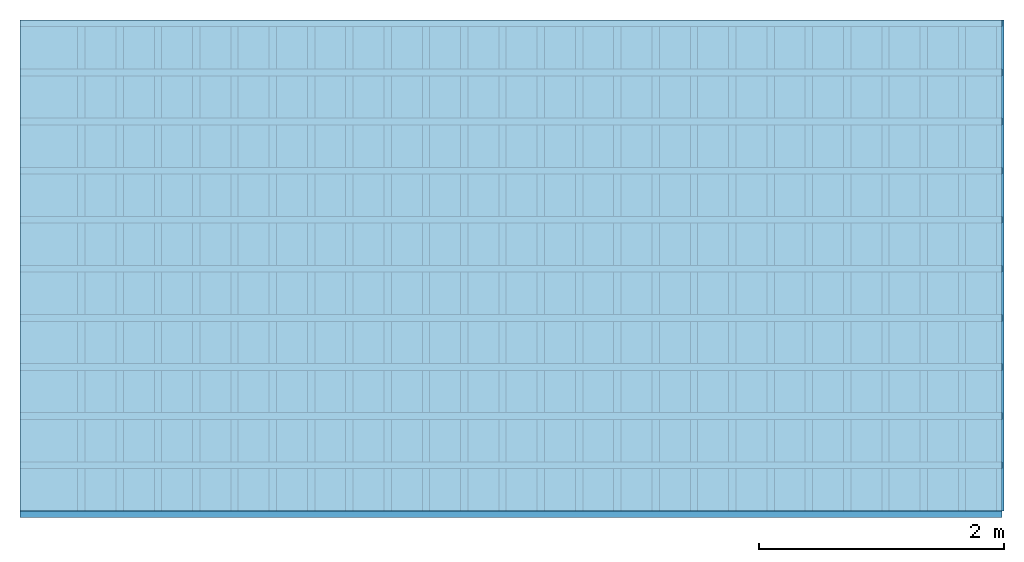
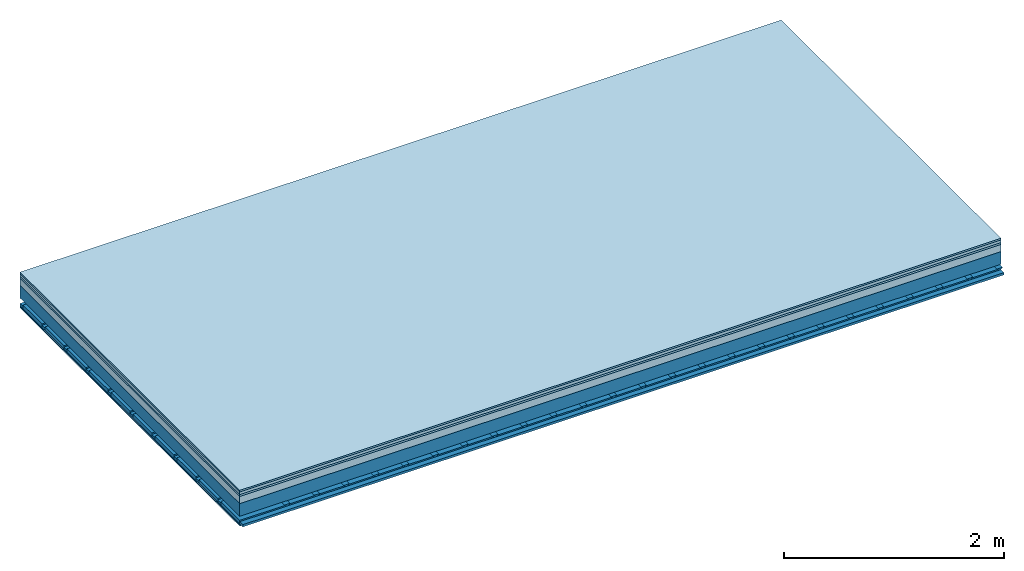
# One storey: 6 plates, 4 members, 1 element without a shape of its own.
"""IFC4 building model written with IfcOpenShell, lengths in metres."""

from ifc_helpers import new_model, si_unit, derived_unit, direction, frame, frame_2d, origin, origin_with_axes, place, context, project, spatial, polyline, rectangle, outline, extrude, material, layer, layer_set, type_object, element, aggregate, save


model = new_model("IFC4")

# Units and contexts
plan_context = context("Plan", 3, precision=1e-05, world=origin(), true_north=direction((0.0, 1.0)))
model_context = context("Model", 3, precision=1e-05, world=origin(), true_north=direction((0.0, 1.0)))
ifc_project = project(units=[si_unit("LENGTHUNIT", "METRE"), derived_unit("SOUNDPRESSUREUNIT", [(si_unit("PRESSUREUNIT", "PASCAL", prefix="MICRO"), 0)]), si_unit("ENERGYUNIT", "JOULE", prefix="MEGA"), si_unit("MASSUNIT", "GRAM", prefix="KILO"), derived_unit("THERMALTRANSMITTANCEUNIT", [(si_unit("POWERUNIT", "WATT"), 1), (si_unit("AREAUNIT", "SQUARE_METRE"), -1), (si_unit("THERMODYNAMICTEMPERATUREUNIT", "KELVIN"), -1)]), derived_unit("AREADENSITYUNIT", [(si_unit("MASSUNIT", "GRAM", prefix="KILO"), 1), (si_unit("AREAUNIT", "SQUARE_METRE"), -1)]), derived_unit("USERDEFINED", [(si_unit("ENERGYUNIT", "JOULE", prefix="MEGA"), 1), (si_unit("AREAUNIT", "SQUARE_METRE"), -1)])], contexts=[plan_context, model_context])

# Site, building, storey
site = spatial("IfcSite", under=ifc_project)
building_placement = place(None, origin())
building = spatial("IfcBuilding", under=site, at=building_placement)
storey_placement = place(building_placement, origin())
storey = spatial("IfcBuildingStorey", under=building, at=storey_placement)

# Slab, members, plates
ifc_material_1 = material(Name="Floor heating system Therm38 longitudinal", Category="03.007")
ifc_layer_1 = layer(ifc_material_1, 0.018, Name="Flooring")
ifc_material_2 = material(Name="Phone Star TRI", Category="03.013")
ifc_layer_2 = layer(ifc_material_2, 0.03, Name="On-material")
ifc_material_3 = material(Name="EP3")
ifc_layer_3 = layer(ifc_material_3, 0.02, Name="Impact sound insulation")
ifc_material_4 = material(Category="03.011")
ifc_layer_4 = layer(ifc_material_4, 0.08, Name="on Supporting structure")
ifc_material_5 = material(Name="no composite action")
ifc_layer_5 = layer(ifc_material_5, 0.0, Name="Bond")
ifc_layer_6 = layer(None, 0.14, Name="Supporting structure")
ifc_material_6 = material(Name="of the art")
ifc_layer_7 = layer(ifc_material_6, 0.0, Name="Bond")
ifc_layer_8 = layer(None, 0.06, Name="Coupling")
ifc_layer_9 = layer(None, 0.025, Name="Battens / profiles")
ifc_layer_10 = layer(ifc_material_2, 0.0125, Name="Ceiling covering 1st layer")
ifc_material_7 = material(Name="Plasterboard type A", Category="03.008")
ifc_layer_11 = layer(ifc_material_7, 0.0125, Name="Ceiling covering layer 2")
ifc_material_8 = material(Name="joints", Category="04.017")
ifc_layer_12 = layer(ifc_material_8, 0.0, Name="Surface / treatment")
ifc_layer_set = layer_set([ifc_layer_1, ifc_layer_2, ifc_layer_3, ifc_layer_4, ifc_layer_5, ifc_layer_6, ifc_layer_7, ifc_layer_8, ifc_layer_9, ifc_layer_10, ifc_layer_11, ifc_layer_12])
slab_type = type_object("IfcSlabType", Name="A2453", PredefinedType="NOTDEFINED", material=ifc_layer_set)
slab_placement = place(None, frame((0.0, 0.0, 0.0), z_axis=(0.0, 0.0, -1.0), x_axis=(1.0, 0.0, 0.0)))
slab = element("IfcSlab", 1, at=slab_placement, inside=storey, type_object=slab_type, material=ifc_layer_set, Name="Slab #1")
ifc_material_9 = material()
member_1_placement = place(slab_placement, origin())
member_1 = element("IfcMember", 2, at=member_1_placement, material=ifc_material_9, Name="Supporting structure", context=plan_context, shape_type="SweptSolid", body=[
    extrude(rectangle(XDim=1.0, YDim=0.14, at=frame_2d((0.5, 0.07), x_axis=(1.0, 0.0))), frame((0.0, 4.0, 0.148), z_axis=(0.0, -1.0, 0.0), x_axis=(1.0, 0.0, 0.0)), (0.0, 0.0, 1.0), 4.0),
    extrude(rectangle(XDim=1.0, YDim=0.14, at=frame_2d((0.5, 0.07), x_axis=(1.0, 0.0))), frame((1.0, 4.0, 0.148), z_axis=(0.0, -1.0, 0.0), x_axis=(1.0, 0.0, 0.0)), (0.0, 0.0, 1.0), 4.0),
    extrude(rectangle(XDim=1.0, YDim=0.14, at=frame_2d((0.5, 0.07), x_axis=(1.0, 0.0))), frame((2.0, 4.0, 0.148), z_axis=(0.0, -1.0, 0.0), x_axis=(1.0, 0.0, 0.0)), (0.0, 0.0, 1.0), 4.0),
    extrude(rectangle(XDim=1.0, YDim=0.14, at=frame_2d((0.5, 0.07), x_axis=(1.0, 0.0))), frame((3.0, 4.0, 0.148), z_axis=(0.0, -1.0, 0.0), x_axis=(1.0, 0.0, 0.0)), (0.0, 0.0, 1.0), 4.0),
    extrude(rectangle(XDim=1.0, YDim=0.14, at=frame_2d((0.5, 0.07), x_axis=(1.0, 0.0))), frame((4.0, 4.0, 0.148), z_axis=(0.0, -1.0, 0.0), x_axis=(1.0, 0.0, 0.0)), (0.0, 0.0, 1.0), 4.0),
    extrude(rectangle(XDim=1.0, YDim=0.14, at=frame_2d((0.5, 0.07), x_axis=(1.0, 0.0))), frame((5.0, 4.0, 0.148), z_axis=(0.0, -1.0, 0.0), x_axis=(1.0, 0.0, 0.0)), (0.0, 0.0, 1.0), 4.0),
    extrude(rectangle(XDim=1.0, YDim=0.14, at=frame_2d((0.5, 0.07), x_axis=(1.0, 0.0))), frame((6.0, 4.0, 0.148), z_axis=(0.0, -1.0, 0.0), x_axis=(1.0, 0.0, 0.0)), (0.0, 0.0, 1.0), 4.0),
    extrude(rectangle(XDim=1.0, YDim=0.14, at=frame_2d((0.5, 0.07), x_axis=(1.0, 0.0))), frame((7.0, 4.0, 0.148), z_axis=(0.0, -1.0, 0.0), x_axis=(1.0, 0.0, 0.0)), (0.0, 0.0, 1.0), 4.0),
])
ifc_material_10 = material()
member_2_placement = place(slab_placement, origin())
member_2 = element("IfcMember", 3, at=member_2_placement, material=ifc_material_10, Name="Coupling", context=plan_context, shape_type="SweptSolid", body=[
    extrude(outline(polyline([(0.0, 0.0), (0.06, 0.0), (0.04, 0.02), (0.02, 0.02), (0.0, 0.0)])), frame((0.47, 4.0, 0.328), z_axis=(0.0, -1.0, 0.0), x_axis=(1.0, 0.0, 0.0)), (0.0, 0.0, 1.0), 4.0),
    extrude(outline(polyline([(0.0, 0.0), (0.06, 0.0), (0.04, 0.02), (0.02, 0.02), (0.0, 0.0)])), frame((0.782, 4.0, 0.328), z_axis=(0.0, -1.0, 0.0), x_axis=(1.0, 0.0, 0.0)), (0.0, 0.0, 1.0), 4.0),
    extrude(outline(polyline([(0.0, 0.0), (0.06, 0.0), (0.04, 0.02), (0.02, 0.02), (0.0, 0.0)])), frame((1.094, 4.0, 0.328), z_axis=(0.0, -1.0, 0.0), x_axis=(1.0, 0.0, 0.0)), (0.0, 0.0, 1.0), 4.0),
    extrude(outline(polyline([(0.0, 0.0), (0.06, 0.0), (0.04, 0.02), (0.02, 0.02), (0.0, 0.0)])), frame((1.406, 4.0, 0.328), z_axis=(0.0, -1.0, 0.0), x_axis=(1.0, 0.0, 0.0)), (0.0, 0.0, 1.0), 4.0),
    extrude(outline(polyline([(0.0, 0.0), (0.06, 0.0), (0.04, 0.02), (0.02, 0.02), (0.0, 0.0)])), frame((1.718, 4.0, 0.328), z_axis=(0.0, -1.0, 0.0), x_axis=(1.0, 0.0, 0.0)), (0.0, 0.0, 1.0), 4.0),
    extrude(outline(polyline([(0.0, 0.0), (0.06, 0.0), (0.04, 0.02), (0.02, 0.02), (0.0, 0.0)])), frame((2.03, 4.0, 0.328), z_axis=(0.0, -1.0, 0.0), x_axis=(1.0, 0.0, 0.0)), (0.0, 0.0, 1.0), 4.0),
    extrude(outline(polyline([(0.0, 0.0), (0.06, 0.0), (0.04, 0.02), (0.02, 0.02), (0.0, 0.0)])), frame((2.342, 4.0, 0.328), z_axis=(0.0, -1.0, 0.0), x_axis=(1.0, 0.0, 0.0)), (0.0, 0.0, 1.0), 4.0),
    extrude(outline(polyline([(0.0, 0.0), (0.06, 0.0), (0.04, 0.02), (0.02, 0.02), (0.0, 0.0)])), frame((2.654, 4.0, 0.328), z_axis=(0.0, -1.0, 0.0), x_axis=(1.0, 0.0, 0.0)), (0.0, 0.0, 1.0), 4.0),
    extrude(outline(polyline([(0.0, 0.0), (0.06, 0.0), (0.04, 0.02), (0.02, 0.02), (0.0, 0.0)])), frame((2.966, 4.0, 0.328), z_axis=(0.0, -1.0, 0.0), x_axis=(1.0, 0.0, 0.0)), (0.0, 0.0, 1.0), 4.0),
    extrude(outline(polyline([(0.0, 0.0), (0.06, 0.0), (0.04, 0.02), (0.02, 0.02), (0.0, 0.0)])), frame((3.278, 4.0, 0.328), z_axis=(0.0, -1.0, 0.0), x_axis=(1.0, 0.0, 0.0)), (0.0, 0.0, 1.0), 4.0),
    extrude(outline(polyline([(0.0, 0.0), (0.06, 0.0), (0.04, 0.02), (0.02, 0.02), (0.0, 0.0)])), frame((3.59, 4.0, 0.328), z_axis=(0.0, -1.0, 0.0), x_axis=(1.0, 0.0, 0.0)), (0.0, 0.0, 1.0), 4.0),
    extrude(outline(polyline([(0.0, 0.0), (0.06, 0.0), (0.04, 0.02), (0.02, 0.02), (0.0, 0.0)])), frame((3.902, 4.0, 0.328), z_axis=(0.0, -1.0, 0.0), x_axis=(1.0, 0.0, 0.0)), (0.0, 0.0, 1.0), 4.0),
    extrude(outline(polyline([(0.0, 0.0), (0.06, 0.0), (0.04, 0.02), (0.02, 0.02), (0.0, 0.0)])), frame((4.214, 4.0, 0.328), z_axis=(0.0, -1.0, 0.0), x_axis=(1.0, 0.0, 0.0)), (0.0, 0.0, 1.0), 4.0),
    extrude(outline(polyline([(0.0, 0.0), (0.06, 0.0), (0.04, 0.02), (0.02, 0.02), (0.0, 0.0)])), frame((4.526, 4.0, 0.328), z_axis=(0.0, -1.0, 0.0), x_axis=(1.0, 0.0, 0.0)), (0.0, 0.0, 1.0), 4.0),
    extrude(outline(polyline([(0.0, 0.0), (0.06, 0.0), (0.04, 0.02), (0.02, 0.02), (0.0, 0.0)])), frame((4.838, 4.0, 0.328), z_axis=(0.0, -1.0, 0.0), x_axis=(1.0, 0.0, 0.0)), (0.0, 0.0, 1.0), 4.0),
    extrude(outline(polyline([(0.0, 0.0), (0.06, 0.0), (0.04, 0.02), (0.02, 0.02), (0.0, 0.0)])), frame((5.15, 4.0, 0.328), z_axis=(0.0, -1.0, 0.0), x_axis=(1.0, 0.0, 0.0)), (0.0, 0.0, 1.0), 4.0),
    extrude(outline(polyline([(0.0, 0.0), (0.06, 0.0), (0.04, 0.02), (0.02, 0.02), (0.0, 0.0)])), frame((5.462, 4.0, 0.328), z_axis=(0.0, -1.0, 0.0), x_axis=(1.0, 0.0, 0.0)), (0.0, 0.0, 1.0), 4.0),
    extrude(outline(polyline([(0.0, 0.0), (0.06, 0.0), (0.04, 0.02), (0.02, 0.02), (0.0, 0.0)])), frame((5.774, 4.0, 0.328), z_axis=(0.0, -1.0, 0.0), x_axis=(1.0, 0.0, 0.0)), (0.0, 0.0, 1.0), 4.0),
    extrude(outline(polyline([(0.0, 0.0), (0.06, 0.0), (0.04, 0.02), (0.02, 0.02), (0.0, 0.0)])), frame((6.086, 4.0, 0.328), z_axis=(0.0, -1.0, 0.0), x_axis=(1.0, 0.0, 0.0)), (0.0, 0.0, 1.0), 4.0),
    extrude(outline(polyline([(0.0, 0.0), (0.06, 0.0), (0.04, 0.02), (0.02, 0.02), (0.0, 0.0)])), frame((6.398, 4.0, 0.328), z_axis=(0.0, -1.0, 0.0), x_axis=(1.0, 0.0, 0.0)), (0.0, 0.0, 1.0), 4.0),
    extrude(outline(polyline([(0.0, 0.0), (0.06, 0.0), (0.04, 0.02), (0.02, 0.02), (0.0, 0.0)])), frame((6.71, 4.0, 0.328), z_axis=(0.0, -1.0, 0.0), x_axis=(1.0, 0.0, 0.0)), (0.0, 0.0, 1.0), 4.0),
    extrude(outline(polyline([(0.0, 0.0), (0.06, 0.0), (0.04, 0.02), (0.02, 0.02), (0.0, 0.0)])), frame((7.022, 4.0, 0.328), z_axis=(0.0, -1.0, 0.0), x_axis=(1.0, 0.0, 0.0)), (0.0, 0.0, 1.0), 4.0),
    extrude(outline(polyline([(0.0, 0.0), (0.06, 0.0), (0.04, 0.02), (0.02, 0.02), (0.0, 0.0)])), frame((7.334, 4.0, 0.328), z_axis=(0.0, -1.0, 0.0), x_axis=(1.0, 0.0, 0.0)), (0.0, 0.0, 1.0), 4.0),
    extrude(outline(polyline([(0.0, 0.0), (0.06, 0.0), (0.04, 0.02), (0.02, 0.02), (0.0, 0.0)])), frame((7.646, 4.0, 0.328), z_axis=(0.0, -1.0, 0.0), x_axis=(1.0, 0.0, 0.0)), (0.0, 0.0, 1.0), 4.0),
    extrude(outline(polyline([(0.0, 0.0), (0.06, 0.0), (0.04, 0.02), (0.02, 0.02), (0.0, 0.0)])), frame((7.958, 4.0, 0.328), z_axis=(0.0, -1.0, 0.0), x_axis=(1.0, 0.0, 0.0)), (0.0, 0.0, 1.0), 4.0),
])
ifc_material_11 = material()
member_3_placement = place(slab_placement, origin())
member_3 = element("IfcMember", 4, at=member_3_placement, material=ifc_material_11, Name="Battens / profiles", context=plan_context, shape_type="SweptSolid", body=[
    extrude(rectangle(XDim=0.055, YDim=0.025, at=frame_2d((0.0275, 0.0125), x_axis=(1.0, 0.0))), frame((0.0, 0.0, 0.348), z_axis=(1.0, 0.0, 0.0), x_axis=(0.0, 1.0, 0.0)), (0.0, 0.0, 1.0), 8.0),
    extrude(rectangle(XDim=0.055, YDim=0.025, at=frame_2d((0.0275, 0.0125), x_axis=(1.0, 0.0))), frame((0.0, 0.4, 0.348), z_axis=(1.0, 0.0, 0.0), x_axis=(0.0, 1.0, 0.0)), (0.0, 0.0, 1.0), 8.0),
    extrude(rectangle(XDim=0.055, YDim=0.025, at=frame_2d((0.0275, 0.0125), x_axis=(1.0, 0.0))), frame((0.0, 0.8, 0.348), z_axis=(1.0, 0.0, 0.0), x_axis=(0.0, 1.0, 0.0)), (0.0, 0.0, 1.0), 8.0),
    extrude(rectangle(XDim=0.055, YDim=0.025, at=frame_2d((0.0275, 0.0125), x_axis=(1.0, 0.0))), frame((0.0, 1.2, 0.348), z_axis=(1.0, 0.0, 0.0), x_axis=(0.0, 1.0, 0.0)), (0.0, 0.0, 1.0), 8.0),
    extrude(rectangle(XDim=0.055, YDim=0.025, at=frame_2d((0.0275, 0.0125), x_axis=(1.0, 0.0))), frame((0.0, 1.6, 0.348), z_axis=(1.0, 0.0, 0.0), x_axis=(0.0, 1.0, 0.0)), (0.0, 0.0, 1.0), 8.0),
    extrude(rectangle(XDim=0.055, YDim=0.025, at=frame_2d((0.0275, 0.0125), x_axis=(1.0, 0.0))), frame((0.0, 2.0, 0.348), z_axis=(1.0, 0.0, 0.0), x_axis=(0.0, 1.0, 0.0)), (0.0, 0.0, 1.0), 8.0),
    extrude(rectangle(XDim=0.055, YDim=0.025, at=frame_2d((0.0275, 0.0125), x_axis=(1.0, 0.0))), frame((0.0, 2.4, 0.348), z_axis=(1.0, 0.0, 0.0), x_axis=(0.0, 1.0, 0.0)), (0.0, 0.0, 1.0), 8.0),
    extrude(rectangle(XDim=0.055, YDim=0.025, at=frame_2d((0.0275, 0.0125), x_axis=(1.0, 0.0))), frame((0.0, 2.8, 0.348), z_axis=(1.0, 0.0, 0.0), x_axis=(0.0, 1.0, 0.0)), (0.0, 0.0, 1.0), 8.0),
    extrude(rectangle(XDim=0.055, YDim=0.025, at=frame_2d((0.0275, 0.0125), x_axis=(1.0, 0.0))), frame((0.0, 3.2, 0.348), z_axis=(1.0, 0.0, 0.0), x_axis=(0.0, 1.0, 0.0)), (0.0, 0.0, 1.0), 8.0),
    extrude(rectangle(XDim=0.055, YDim=0.025, at=frame_2d((0.0275, 0.0125), x_axis=(1.0, 0.0))), frame((0.0, 3.6, 0.348), z_axis=(1.0, 0.0, 0.0), x_axis=(0.0, 1.0, 0.0)), (0.0, 0.0, 1.0), 8.0),
    extrude(rectangle(XDim=0.055, YDim=0.025, at=frame_2d((0.0275, 0.0125), x_axis=(1.0, 0.0))), frame((0.0, 4.0, 0.348), z_axis=(1.0, 0.0, 0.0), x_axis=(0.0, 1.0, 0.0)), (0.0, 0.0, 1.0), 8.0),
])
ifc_material_12 = material()
member_4_placement = place(slab_placement, origin())
member_4 = element("IfcMember", 5, at=member_4_placement, material=ifc_material_12, Name="Cavity", context=plan_context, shape_type="SweptSolid", body=[
    extrude(rectangle(XDim=0.345, YDim=0.04, at=frame_2d((0.1725, 0.02), x_axis=(1.0, 0.0))), frame((0.0, 0.055, 0.333), z_axis=(1.0, 0.0, 0.0), x_axis=(0.0, 1.0, 0.0)), (0.0, 0.0, 1.0), 8.0),
    extrude(rectangle(XDim=0.345, YDim=0.04, at=frame_2d((0.1725, 0.02), x_axis=(1.0, 0.0))), frame((0.0, 0.455, 0.333), z_axis=(1.0, 0.0, 0.0), x_axis=(0.0, 1.0, 0.0)), (0.0, 0.0, 1.0), 8.0),
    extrude(rectangle(XDim=0.345, YDim=0.04, at=frame_2d((0.1725, 0.02), x_axis=(1.0, 0.0))), frame((0.0, 0.855, 0.333), z_axis=(1.0, 0.0, 0.0), x_axis=(0.0, 1.0, 0.0)), (0.0, 0.0, 1.0), 8.0),
    extrude(rectangle(XDim=0.345, YDim=0.04, at=frame_2d((0.1725, 0.02), x_axis=(1.0, 0.0))), frame((0.0, 1.255, 0.333), z_axis=(1.0, 0.0, 0.0), x_axis=(0.0, 1.0, 0.0)), (0.0, 0.0, 1.0), 8.0),
    extrude(rectangle(XDim=0.345, YDim=0.04, at=frame_2d((0.1725, 0.02), x_axis=(1.0, 0.0))), frame((0.0, 1.655, 0.333), z_axis=(1.0, 0.0, 0.0), x_axis=(0.0, 1.0, 0.0)), (0.0, 0.0, 1.0), 8.0),
    extrude(rectangle(XDim=0.345, YDim=0.04, at=frame_2d((0.1725, 0.02), x_axis=(1.0, 0.0))), frame((0.0, 2.055, 0.333), z_axis=(1.0, 0.0, 0.0), x_axis=(0.0, 1.0, 0.0)), (0.0, 0.0, 1.0), 8.0),
    extrude(rectangle(XDim=0.345, YDim=0.04, at=frame_2d((0.1725, 0.02), x_axis=(1.0, 0.0))), frame((0.0, 2.455, 0.333), z_axis=(1.0, 0.0, 0.0), x_axis=(0.0, 1.0, 0.0)), (0.0, 0.0, 1.0), 8.0),
    extrude(rectangle(XDim=0.345, YDim=0.04, at=frame_2d((0.1725, 0.02), x_axis=(1.0, 0.0))), frame((0.0, 2.855, 0.333), z_axis=(1.0, 0.0, 0.0), x_axis=(0.0, 1.0, 0.0)), (0.0, 0.0, 1.0), 8.0),
    extrude(rectangle(XDim=0.345, YDim=0.04, at=frame_2d((0.1725, 0.02), x_axis=(1.0, 0.0))), frame((0.0, 3.255, 0.333), z_axis=(1.0, 0.0, 0.0), x_axis=(0.0, 1.0, 0.0)), (0.0, 0.0, 1.0), 8.0),
    extrude(rectangle(XDim=0.345, YDim=0.04, at=frame_2d((0.1725, 0.02), x_axis=(1.0, 0.0))), frame((0.0, 3.655, 0.333), z_axis=(1.0, 0.0, 0.0), x_axis=(0.0, 1.0, 0.0)), (0.0, 0.0, 1.0), 8.0),
])
plate_1_placement = place(slab_placement, origin())
plate_1 = element("IfcPlate", 6, at=plate_1_placement, material=ifc_material_1, Name="Flooring", context=plan_context, shape_type="SweptSolid", body=[
    extrude(rectangle(XDim=8.0, YDim=4.0, at=frame_2d((4.0, 2.0), x_axis=(1.0, 0.0))), origin_with_axes(), (0.0, 0.0, 1.0), 0.018),
])
plate_2_placement = place(slab_placement, origin())
plate_2 = element("IfcPlate", 7, at=plate_2_placement, material=ifc_material_2, Name="On-material", context=plan_context, shape_type="SweptSolid", body=[
    extrude(rectangle(XDim=8.0, YDim=4.0, at=frame_2d((4.0, 2.0), x_axis=(1.0, 0.0))), frame((0.0, 0.0, 0.018), z_axis=(0.0, 0.0, 1.0), x_axis=(1.0, 0.0, 0.0)), (0.0, 0.0, 1.0), 0.03),
])
plate_3_placement = place(slab_placement, origin())
plate_3 = element("IfcPlate", 8, at=plate_3_placement, material=ifc_material_3, Name="Impact sound insulation", context=plan_context, shape_type="SweptSolid", body=[
    extrude(rectangle(XDim=8.0, YDim=4.0, at=frame_2d((4.0, 2.0), x_axis=(1.0, 0.0))), frame((0.0, 0.0, 0.048), z_axis=(0.0, 0.0, 1.0), x_axis=(1.0, 0.0, 0.0)), (0.0, 0.0, 1.0), 0.02),
])
plate_4_placement = place(slab_placement, origin())
plate_4 = element("IfcPlate", 9, at=plate_4_placement, material=ifc_material_4, Name="on Supporting structure", context=plan_context, shape_type="SweptSolid", body=[
    extrude(rectangle(XDim=8.0, YDim=4.0, at=frame_2d((4.0, 2.0), x_axis=(1.0, 0.0))), frame((0.0, 0.0, 0.068), z_axis=(0.0, 0.0, 1.0), x_axis=(1.0, 0.0, 0.0)), (0.0, 0.0, 1.0), 0.08),
])
plate_5_placement = place(slab_placement, origin())
plate_5 = element("IfcPlate", 10, at=plate_5_placement, material=ifc_material_2, Name="Ceiling covering 1st layer", context=plan_context, shape_type="SweptSolid", body=[
    extrude(rectangle(XDim=8.0, YDim=4.0, at=frame_2d((4.0, 2.0), x_axis=(1.0, 0.0))), frame((0.0, 0.0, 0.373), z_axis=(0.0, 0.0, 1.0), x_axis=(1.0, 0.0, 0.0)), (0.0, 0.0, 1.0), 0.0125),
])
plate_6_placement = place(slab_placement, origin())
plate_6 = element("IfcPlate", 11, at=plate_6_placement, material=ifc_material_7, Name="Ceiling covering layer 2", context=plan_context, shape_type="SweptSolid", body=[
    extrude(rectangle(XDim=8.0, YDim=4.0, at=frame_2d((4.0, 2.0), x_axis=(1.0, 0.0))), frame((0.0, 0.0, 0.3855), z_axis=(0.0, 0.0, 1.0), x_axis=(1.0, 0.0, 0.0)), (0.0, 0.0, 1.0), 0.0125),
])
aggregate(slab, [plate_1, plate_2, plate_3, plate_4, member_1, member_2, member_3, member_4, plate_5, plate_6])

save(model, "model.ifc")
